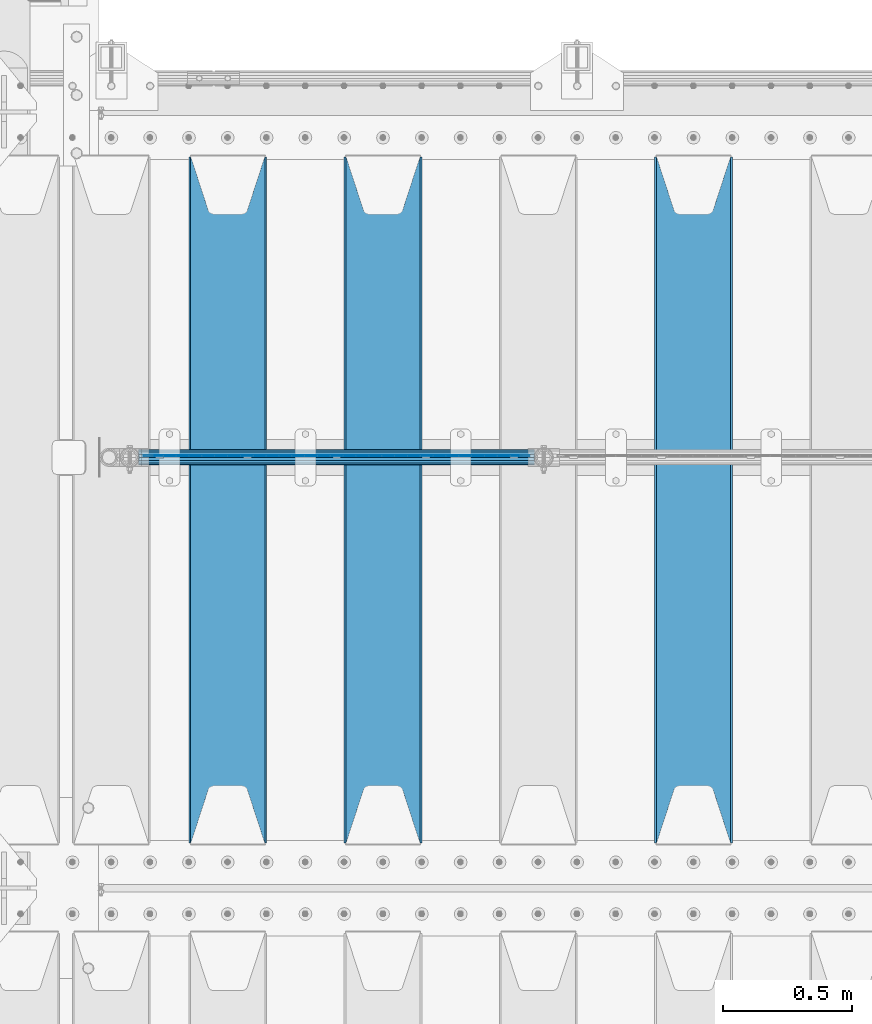
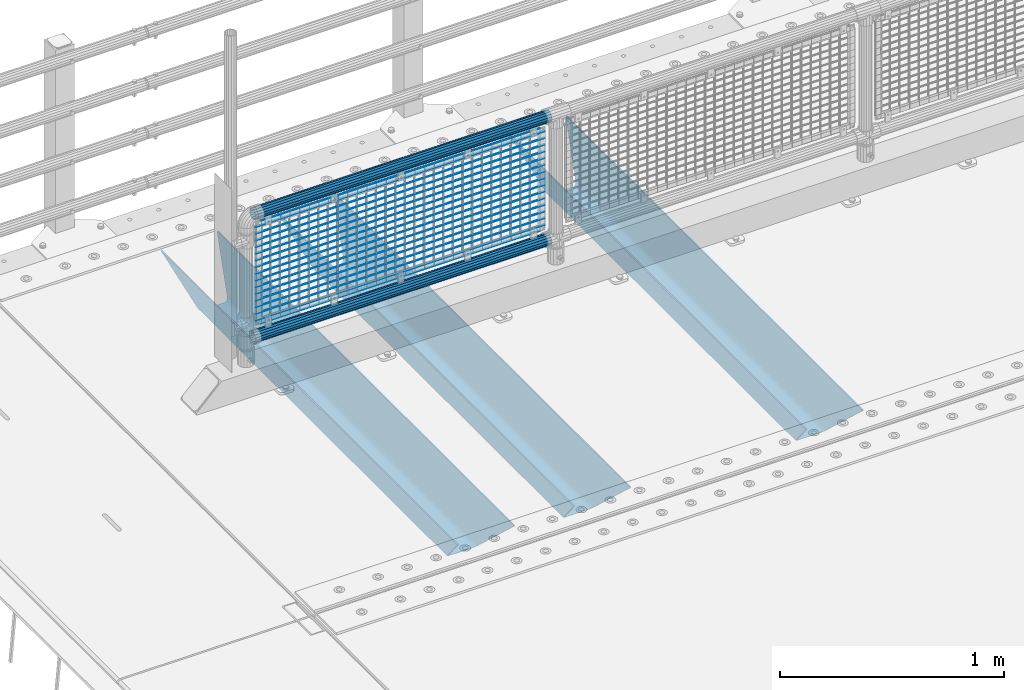
# One storey, part 120 of 247: 22 beams.
"""IFC2X3 building model written with IfcOpenShell, lengths in millimetres."""

from ifc_helpers import new_model, si_unit, frame, origin_with_axes, place, context, subcontext, project, spatial, faceted_brep, material, type_object, element, save


model = new_model("IFC2X3")

# Units and contexts
model_context = context("Model", 3, precision=1e-05, world=origin_with_axes())
body_context = subcontext(model_context, "Body", "Model", "MODEL_VIEW")
ifc_project = project(units=[si_unit("LENGTHUNIT", "METRE", prefix="MILLI"), si_unit("AREAUNIT", "SQUARE_METRE"), si_unit("VOLUMEUNIT", "CUBIC_METRE"), si_unit("MASSUNIT", "GRAM", prefix="KILO"), si_unit("TIMEUNIT", "SECOND"), si_unit("PLANEANGLEUNIT", "RADIAN"), si_unit("SOLIDANGLEUNIT", "STERADIAN"), si_unit("THERMODYNAMICTEMPERATUREUNIT", "DEGREE_CELSIUS"), si_unit("LUMINOUSINTENSITYUNIT", "LUMEN")], contexts=[model_context])

# Site, building, storey
site_placement = place(None, origin_with_axes())
site = spatial("IfcSite", under=ifc_project, at=site_placement, CompositionType="ELEMENT")
building_placement = place(site_placement, origin_with_axes())
building = spatial("IfcBuilding", under=site, at=building_placement, Name="Standard", CompositionType="ELEMENT")
storey_placement = place(building_placement, origin_with_axes())
storey = spatial("IfcBuildingStorey", under=building, at=storey_placement, Name="Undefined", CompositionType="ELEMENT", Elevation=0.0)

# Beams
ifc_material_1 = material(Name="STEEL/S355N")
beam_type_1 = type_object("IfcBeamType", PredefinedType="NOTDEFINED")
beam_1_placement = place(storey_placement, frame((2800.0, 6175.0, -115.0), z_axis=(0.0, 0.0, 1.0), x_axis=(0.0, 1.0, 0.0)))
element("IfcBeam", 1, at=beam_1_placement, inside=storey, type_object=beam_type_1, material=ifc_material_1, context=body_context, shape_type="Brep", body=[
    faceted_brep([(0.0, 150.0, 115.0), (0.0, 143.689999999999, 115.0), (2650.00000000297, 143.689999999999, 115.0), (2650.00000000297, 150.0, 115.0), (2650.00000000297, 142.059565218402, 110.0000000031), (2650.00000000297, 148.369565218403, 110.0000000031), (2441.90079219208, -80.1103600731112, -98.0992078077845), (2437.7588105432, -77.5672621345584, -102.241189456673), (2434.06523489746, -74.4080125315522, -105.934765102404), (2430.91086095089, -70.710272125576, -109.089139048974), (2428.37322971128, -66.5649389910068, -111.626770288588), (2426.51472138054, -62.0739139532889, -113.485278619323), (2425.38102192091, -57.3475956567672, -114.618978078955), (2424.99999999987, -52.5021667386536, -115.0), (2424.99999999987, 52.5021667386536, -115.0), (2425.38102192091, 57.3475956567672, -114.618978078955), (2426.51472138054, 62.0739139532889, -113.485278619323), (2428.37322971128, 66.5649389910068, -111.626770288588), (2430.91086095089, 70.710272125576, -109.089139048974), (2434.06523489746, 74.4080125315522, -105.934765102404), (2437.7588105432, 77.5672621345584, -102.241189456673), (2441.90079219208, 80.1103600731112, -98.0992078077846), (2446.38936140511, 81.9747917625791, -93.6106385947584), (2448.24948500409, 76.2713538057251, -91.7505149957729), (2444.62967112262, 74.76777986261, -95.3703288772456), (2441.28936334126, 72.7168944282894, -98.710636658607), (2438.31067330438, 70.1691124903846, -101.689326695487), (2435.76682334747, 67.1870637758839, -104.233176652398), (2433.72034654133, 63.8440531834895, -106.279653458539), (2432.22154950041, 60.222258798236, -107.778450499454), (2431.30727574265, 56.4107117849089, -108.692724257221), (2430.99999999987, 52.5031078186876, -109.0), (2430.99999999987, -52.5031078186876, -109.0), (2431.30727574265, -56.4107117849089, -108.692724257221), (2432.22154950041, -60.222258798236, -107.778450499454), (2433.72034654133, -63.8440531834895, -106.279653458539), (2435.76682334747, -67.1870637758839, -104.233176652398), (2438.31067330438, -70.1691124903846, -101.689326695487), (2441.28936334126, -72.7168944282894, -98.7106366586071), (2444.62967112262, -74.76777986261, -95.3703288772457), (2448.24948500409, -76.2713538057251, -91.7505149957729), (2650.00000000297, -142.059565218402, 110.0000000031), (2650.00000000297, -148.369565218403, 110.0000000031), (2446.38936140511, -81.9747917625791, -93.6106385947584), (2650.00000000297, -143.689999999999, 115.0), (2650.00000000297, -150.0, 115.0), (0.0, -143.689999999999, 115.0), (0.0, -150.0, 115.0), (0.0, -148.369565218261, 110.000000002663), (203.610638597422, -81.9747917625791, -93.6106385947584), (208.099207810448, -80.1103600731112, -98.0992078077845), (212.241189459336, -77.5672621345584, -102.241189456673), (215.934765105068, -74.4080125315522, -105.934765102404), (219.089139051637, -70.710272125576, -109.089139048974), (221.626770291251, -66.5649389910068, -111.626770288588), (223.485278621985, -62.0739139532889, -113.485278619323), (224.618978081617, -57.3475956567672, -114.618978078955), (225.000000002663, -52.5021667386536, -115.0), (225.000000002663, 52.5021667386536, -115.0), (224.618978081617, 57.3475956567672, -114.618978078955), (223.485278621985, 62.0739139532889, -113.485278619323), (221.626770291251, 66.5649389910068, -111.626770288588), (219.089139051637, 70.710272125576, -109.089139048974), (215.934765105068, 74.4080125315522, -105.934765102404), (212.241189459336, 77.5672621345584, -102.241189456673), (208.099207810448, 80.1103600731112, -98.0992078077846), (203.610638597422, 81.9747917625791, -93.6106385947584), (0.0, 148.369565218261, 110.000000002663), (0.0, 142.05956521826, 110.000000002663), (201.750514998436, 76.2713538057251, -91.7505149957729), (205.370328879908, 74.76777986261, -95.3703288772456), (208.710636661271, 72.7168944282894, -98.710636658607), (211.68932669815, 70.1691124903846, -101.689326695487), (214.233176655061, 67.1870637758839, -104.233176652398), (216.279653461202, 63.8440531834895, -106.279653458539), (217.778450502117, 60.222258798236, -107.778450499454), (218.692724259885, 56.4107117849089, -108.692724257221), (219.000000002663, 52.5031078186876, -109.0), (219.000000002663, -52.5031078186876, -109.0), (218.692724259885, -56.4107117849089, -108.692724257221), (217.778450502117, -60.222258798236, -107.778450499454), (216.279653461202, -63.8440531834895, -106.279653458539), (214.233176655061, -67.1870637758839, -104.233176652398), (211.68932669815, -70.1691124903846, -101.689326695487), (208.710636661271, -72.7168944282894, -98.7106366586071), (205.370328879908, -74.76777986261, -95.3703288772457), (201.750514998436, -76.2713538057251, -91.7505149957729), (0.0, -142.05956521826, 110.000000002663)], [[[0, 1, 2, 3]], [[3, 2, 4, 5]], [[6, 7, 8, 9, 10, 11, 12, 13, 14, 15, 16, 17, 18, 19, 20, 21, 22, 5, 4, 23, 24, 25, 26, 27, 28, 29, 30, 31, 32, 33, 34, 35, 36, 37, 38, 39, 40, 41, 42, 43]], [[44, 45, 42, 41]], [[46, 47, 45, 44]], [[43, 42, 45, 47, 48, 49]], [[6, 43, 49, 50]], [[7, 6, 50, 51]], [[8, 7, 51, 52]], [[9, 8, 52, 53]], [[10, 9, 53, 54]], [[11, 10, 54, 55]], [[12, 11, 55, 56]], [[13, 12, 56, 57]], [[14, 13, 57, 58]], [[15, 14, 58, 59]], [[16, 15, 59, 60]], [[17, 16, 60, 61]], [[18, 17, 61, 62]], [[19, 18, 62, 63]], [[20, 19, 63, 64]], [[21, 20, 64, 65]], [[22, 21, 65, 66]], [[0, 3, 5, 22, 66, 67]], [[1, 0, 67, 68]], [[23, 4, 2, 1, 68, 69]], [[24, 23, 69, 70]], [[25, 24, 70, 71]], [[26, 25, 71, 72]], [[27, 26, 72, 73]], [[28, 27, 73, 74]], [[29, 28, 74, 75]], [[30, 29, 75, 76]], [[31, 30, 76, 77]], [[32, 31, 77, 78]], [[33, 32, 78, 79]], [[34, 33, 79, 80]], [[35, 34, 80, 81]], [[36, 35, 81, 82]], [[37, 36, 82, 83]], [[38, 37, 83, 84]], [[39, 38, 84, 85]], [[40, 39, 85, 86]], [[46, 44, 41, 40, 86, 87]], [[47, 46, 87, 48]], [[86, 85, 84, 83, 82, 81, 80, 79, 78, 77, 76, 75, 74, 73, 72, 71, 70, 69, 68, 67, 66, 65, 64, 63, 62, 61, 60, 59, 58, 57, 56, 55, 54, 53, 52, 51, 50, 49, 48, 87]]]),
])
beam_2_placement = place(storey_placement, frame((1600.0, 6175.0, -115.0), z_axis=(0.0, 0.0, 1.0), x_axis=(0.0, 1.0, 0.0)))
element("IfcBeam", 2, at=beam_2_placement, inside=storey, type_object=beam_type_1, material=ifc_material_1, context=body_context, shape_type="Brep", body=[
    faceted_brep([(0.0, 150.0, 115.0), (0.0, 143.689999999999, 115.0), (2650.00000000297, 143.689999999999, 115.0), (2650.00000000297, 150.0, 115.0), (2650.00000000297, 142.059565218402, 110.0000000031), (2650.00000000297, 148.369565218403, 110.0000000031), (2441.90079219208, -80.1103600731112, -98.0992078077845), (2437.7588105432, -77.5672621345584, -102.241189456673), (2434.06523489746, -74.4080125315522, -105.934765102404), (2430.91086095089, -70.710272125576, -109.089139048974), (2428.37322971128, -66.5649389910068, -111.626770288588), (2426.51472138054, -62.0739139532889, -113.485278619323), (2425.38102192091, -57.3475956567672, -114.618978078955), (2424.99999999987, -52.5021667386536, -115.0), (2424.99999999987, 52.5021667386536, -115.0), (2425.38102192091, 57.3475956567672, -114.618978078955), (2426.51472138054, 62.0739139532889, -113.485278619323), (2428.37322971128, 66.5649389910068, -111.626770288588), (2430.91086095089, 70.710272125576, -109.089139048974), (2434.06523489746, 74.4080125315522, -105.934765102404), (2437.7588105432, 77.5672621345584, -102.241189456673), (2441.90079219208, 80.1103600731112, -98.0992078077846), (2446.38936140511, 81.9747917625791, -93.6106385947584), (2448.24948500409, 76.2713538057251, -91.7505149957729), (2444.62967112262, 74.76777986261, -95.3703288772456), (2441.28936334126, 72.7168944282894, -98.710636658607), (2438.31067330438, 70.1691124903846, -101.689326695487), (2435.76682334747, 67.1870637758839, -104.233176652398), (2433.72034654133, 63.8440531834895, -106.279653458539), (2432.22154950041, 60.222258798236, -107.778450499454), (2431.30727574265, 56.4107117849089, -108.692724257221), (2430.99999999987, 52.5031078186876, -109.0), (2430.99999999987, -52.5031078186876, -109.0), (2431.30727574265, -56.4107117849089, -108.692724257221), (2432.22154950041, -60.222258798236, -107.778450499454), (2433.72034654133, -63.8440531834895, -106.279653458539), (2435.76682334747, -67.1870637758839, -104.233176652398), (2438.31067330438, -70.1691124903846, -101.689326695487), (2441.28936334126, -72.7168944282894, -98.7106366586071), (2444.62967112262, -74.76777986261, -95.3703288772457), (2448.24948500409, -76.2713538057251, -91.7505149957729), (2650.00000000297, -142.059565218402, 110.0000000031), (2650.00000000297, -148.369565218403, 110.0000000031), (2446.38936140511, -81.9747917625791, -93.6106385947584), (2650.00000000297, -143.689999999999, 115.0), (2650.00000000297, -150.0, 115.0), (0.0, -143.689999999999, 115.0), (0.0, -150.0, 115.0), (0.0, -148.369565218261, 110.000000002663), (203.610638597422, -81.9747917625791, -93.6106385947584), (208.099207810448, -80.1103600731112, -98.0992078077845), (212.241189459336, -77.5672621345584, -102.241189456673), (215.934765105068, -74.4080125315522, -105.934765102404), (219.089139051637, -70.710272125576, -109.089139048974), (221.626770291251, -66.5649389910068, -111.626770288588), (223.485278621985, -62.0739139532889, -113.485278619323), (224.618978081617, -57.3475956567672, -114.618978078955), (225.000000002663, -52.5021667386536, -115.0), (225.000000002663, 52.5021667386536, -115.0), (224.618978081617, 57.3475956567672, -114.618978078955), (223.485278621985, 62.0739139532889, -113.485278619323), (221.626770291251, 66.5649389910068, -111.626770288588), (219.089139051637, 70.710272125576, -109.089139048974), (215.934765105068, 74.4080125315522, -105.934765102404), (212.241189459336, 77.5672621345584, -102.241189456673), (208.099207810448, 80.1103600731112, -98.0992078077846), (203.610638597422, 81.9747917625791, -93.6106385947584), (0.0, 148.369565218261, 110.000000002663), (0.0, 142.05956521826, 110.000000002663), (201.750514998436, 76.2713538057251, -91.7505149957729), (205.370328879908, 74.76777986261, -95.3703288772456), (208.710636661271, 72.7168944282894, -98.710636658607), (211.68932669815, 70.1691124903846, -101.689326695487), (214.233176655061, 67.1870637758839, -104.233176652398), (216.279653461202, 63.8440531834895, -106.279653458539), (217.778450502117, 60.222258798236, -107.778450499454), (218.692724259885, 56.4107117849089, -108.692724257221), (219.000000002663, 52.5031078186876, -109.0), (219.000000002663, -52.5031078186876, -109.0), (218.692724259885, -56.4107117849089, -108.692724257221), (217.778450502117, -60.222258798236, -107.778450499454), (216.279653461202, -63.8440531834895, -106.279653458539), (214.233176655061, -67.1870637758839, -104.233176652398), (211.68932669815, -70.1691124903846, -101.689326695487), (208.710636661271, -72.7168944282894, -98.7106366586071), (205.370328879908, -74.76777986261, -95.3703288772457), (201.750514998436, -76.2713538057251, -91.7505149957729), (0.0, -142.05956521826, 110.000000002663)], [[[0, 1, 2, 3]], [[3, 2, 4, 5]], [[6, 7, 8, 9, 10, 11, 12, 13, 14, 15, 16, 17, 18, 19, 20, 21, 22, 5, 4, 23, 24, 25, 26, 27, 28, 29, 30, 31, 32, 33, 34, 35, 36, 37, 38, 39, 40, 41, 42, 43]], [[44, 45, 42, 41]], [[46, 47, 45, 44]], [[43, 42, 45, 47, 48, 49]], [[6, 43, 49, 50]], [[7, 6, 50, 51]], [[8, 7, 51, 52]], [[9, 8, 52, 53]], [[10, 9, 53, 54]], [[11, 10, 54, 55]], [[12, 11, 55, 56]], [[13, 12, 56, 57]], [[14, 13, 57, 58]], [[15, 14, 58, 59]], [[16, 15, 59, 60]], [[17, 16, 60, 61]], [[18, 17, 61, 62]], [[19, 18, 62, 63]], [[20, 19, 63, 64]], [[21, 20, 64, 65]], [[22, 21, 65, 66]], [[0, 3, 5, 22, 66, 67]], [[1, 0, 67, 68]], [[23, 4, 2, 1, 68, 69]], [[24, 23, 69, 70]], [[25, 24, 70, 71]], [[26, 25, 71, 72]], [[27, 26, 72, 73]], [[28, 27, 73, 74]], [[29, 28, 74, 75]], [[30, 29, 75, 76]], [[31, 30, 76, 77]], [[32, 31, 77, 78]], [[33, 32, 78, 79]], [[34, 33, 79, 80]], [[35, 34, 80, 81]], [[36, 35, 81, 82]], [[37, 36, 82, 83]], [[38, 37, 83, 84]], [[39, 38, 84, 85]], [[40, 39, 85, 86]], [[46, 44, 41, 40, 86, 87]], [[47, 46, 87, 48]], [[86, 85, 84, 83, 82, 81, 80, 79, 78, 77, 76, 75, 74, 73, 72, 71, 70, 69, 68, 67, 66, 65, 64, 63, 62, 61, 60, 59, 58, 57, 56, 55, 54, 53, 52, 51, 50, 49, 48, 87]]]),
])
beam_3_placement = place(storey_placement, frame((1000.0, 6175.0, -115.0), z_axis=(0.0, 0.0, 1.0), x_axis=(0.0, 1.0, 0.0)))
element("IfcBeam", 3, at=beam_3_placement, inside=storey, type_object=beam_type_1, material=ifc_material_1, context=body_context, shape_type="Brep", body=[
    faceted_brep([(0.0, 150.0, 115.0), (0.0, 143.689999999999, 115.0), (2650.00000000297, 143.689999999999, 115.0), (2650.00000000297, 150.0, 115.0), (2650.00000000297, 142.059565218402, 110.0000000031), (2650.00000000297, 148.369565218403, 110.0000000031), (2441.90079219208, -80.1103600731112, -98.0992078077845), (2437.7588105432, -77.5672621345584, -102.241189456673), (2434.06523489746, -74.4080125315522, -105.934765102404), (2430.91086095089, -70.710272125576, -109.089139048974), (2428.37322971128, -66.5649389910068, -111.626770288588), (2426.51472138054, -62.0739139532889, -113.485278619323), (2425.38102192091, -57.3475956567672, -114.618978078955), (2424.99999999987, -52.5021667386536, -115.0), (2424.99999999987, 52.5021667386536, -115.0), (2425.38102192091, 57.3475956567672, -114.618978078955), (2426.51472138054, 62.0739139532889, -113.485278619323), (2428.37322971128, 66.5649389910068, -111.626770288588), (2430.91086095089, 70.710272125576, -109.089139048974), (2434.06523489746, 74.4080125315522, -105.934765102404), (2437.7588105432, 77.5672621345584, -102.241189456673), (2441.90079219208, 80.1103600731112, -98.0992078077846), (2446.38936140511, 81.9747917625791, -93.6106385947584), (2448.24948500409, 76.2713538057251, -91.7505149957729), (2444.62967112262, 74.76777986261, -95.3703288772456), (2441.28936334126, 72.7168944282894, -98.710636658607), (2438.31067330438, 70.1691124903846, -101.689326695487), (2435.76682334747, 67.1870637758839, -104.233176652398), (2433.72034654133, 63.8440531834895, -106.279653458539), (2432.22154950041, 60.222258798236, -107.778450499454), (2431.30727574265, 56.4107117849089, -108.692724257221), (2430.99999999987, 52.5031078186876, -109.0), (2430.99999999987, -52.5031078186876, -109.0), (2431.30727574265, -56.4107117849089, -108.692724257221), (2432.22154950041, -60.222258798236, -107.778450499454), (2433.72034654133, -63.8440531834895, -106.279653458539), (2435.76682334747, -67.1870637758839, -104.233176652398), (2438.31067330438, -70.1691124903846, -101.689326695487), (2441.28936334126, -72.7168944282894, -98.7106366586071), (2444.62967112262, -74.76777986261, -95.3703288772457), (2448.24948500409, -76.2713538057251, -91.7505149957729), (2650.00000000297, -142.059565218402, 110.0000000031), (2650.00000000297, -148.369565218403, 110.0000000031), (2446.38936140511, -81.9747917625791, -93.6106385947584), (2650.00000000297, -143.689999999999, 115.0), (2650.00000000297, -150.0, 115.0), (0.0, -143.689999999999, 115.0), (0.0, -150.0, 115.0), (0.0, -148.369565218261, 110.000000002663), (203.610638597422, -81.9747917625791, -93.6106385947584), (208.099207810448, -80.1103600731112, -98.0992078077845), (212.241189459336, -77.5672621345584, -102.241189456673), (215.934765105068, -74.4080125315522, -105.934765102404), (219.089139051637, -70.710272125576, -109.089139048974), (221.626770291251, -66.5649389910068, -111.626770288588), (223.485278621985, -62.0739139532889, -113.485278619323), (224.618978081617, -57.3475956567672, -114.618978078955), (225.000000002663, -52.5021667386536, -115.0), (225.000000002663, 52.5021667386536, -115.0), (224.618978081617, 57.3475956567672, -114.618978078955), (223.485278621985, 62.0739139532889, -113.485278619323), (221.626770291251, 66.5649389910068, -111.626770288588), (219.089139051637, 70.710272125576, -109.089139048974), (215.934765105068, 74.4080125315522, -105.934765102404), (212.241189459336, 77.5672621345584, -102.241189456673), (208.099207810448, 80.1103600731112, -98.0992078077846), (203.610638597422, 81.9747917625791, -93.6106385947584), (0.0, 148.369565218261, 110.000000002663), (0.0, 142.05956521826, 110.000000002663), (201.750514998436, 76.2713538057251, -91.7505149957729), (205.370328879908, 74.76777986261, -95.3703288772456), (208.710636661271, 72.7168944282894, -98.710636658607), (211.68932669815, 70.1691124903846, -101.689326695487), (214.233176655061, 67.1870637758839, -104.233176652398), (216.279653461202, 63.8440531834895, -106.279653458539), (217.778450502117, 60.222258798236, -107.778450499454), (218.692724259885, 56.4107117849089, -108.692724257221), (219.000000002663, 52.5031078186876, -109.0), (219.000000002663, -52.5031078186876, -109.0), (218.692724259885, -56.4107117849089, -108.692724257221), (217.778450502117, -60.222258798236, -107.778450499454), (216.279653461202, -63.8440531834895, -106.279653458539), (214.233176655061, -67.1870637758839, -104.233176652398), (211.68932669815, -70.1691124903846, -101.689326695487), (208.710636661271, -72.7168944282894, -98.7106366586071), (205.370328879908, -74.76777986261, -95.3703288772457), (201.750514998436, -76.2713538057251, -91.7505149957729), (0.0, -142.05956521826, 110.000000002663)], [[[0, 1, 2, 3]], [[3, 2, 4, 5]], [[6, 7, 8, 9, 10, 11, 12, 13, 14, 15, 16, 17, 18, 19, 20, 21, 22, 5, 4, 23, 24, 25, 26, 27, 28, 29, 30, 31, 32, 33, 34, 35, 36, 37, 38, 39, 40, 41, 42, 43]], [[44, 45, 42, 41]], [[46, 47, 45, 44]], [[43, 42, 45, 47, 48, 49]], [[6, 43, 49, 50]], [[7, 6, 50, 51]], [[8, 7, 51, 52]], [[9, 8, 52, 53]], [[10, 9, 53, 54]], [[11, 10, 54, 55]], [[12, 11, 55, 56]], [[13, 12, 56, 57]], [[14, 13, 57, 58]], [[15, 14, 58, 59]], [[16, 15, 59, 60]], [[17, 16, 60, 61]], [[18, 17, 61, 62]], [[19, 18, 62, 63]], [[20, 19, 63, 64]], [[21, 20, 64, 65]], [[22, 21, 65, 66]], [[0, 3, 5, 22, 66, 67]], [[1, 0, 67, 68]], [[23, 4, 2, 1, 68, 69]], [[24, 23, 69, 70]], [[25, 24, 70, 71]], [[26, 25, 71, 72]], [[27, 26, 72, 73]], [[28, 27, 73, 74]], [[29, 28, 74, 75]], [[30, 29, 75, 76]], [[31, 30, 76, 77]], [[32, 31, 77, 78]], [[33, 32, 78, 79]], [[34, 33, 79, 80]], [[35, 34, 80, 81]], [[36, 35, 81, 82]], [[37, 36, 82, 83]], [[38, 37, 83, 84]], [[39, 38, 84, 85]], [[40, 39, 85, 86]], [[46, 44, 41, 40, 86, 87]], [[47, 46, 87, 48]], [[86, 85, 84, 83, 82, 81, 80, 79, 78, 77, 76, 75, 74, 73, 72, 71, 70, 69, 68, 67, 66, 65, 64, 63, 62, 61, 60, 59, 58, 57, 56, 55, 54, 53, 52, 51, 50, 49, 48, 87]]]),
])
ifc_material_2 = material()
beam_type_2 = type_object("IfcBeamType", PredefinedType="NOTDEFINED")
beam_4_placement = place(storey_placement, frame((655.85, 7664.5, 969.849999999999), z_axis=(0.0, 0.0, 1.0), x_axis=(1.0, 0.0, 0.0)))
element("IfcBeam", 4, at=beam_4_placement, inside=storey, type_object=beam_type_2, material=ifc_material_2, context=body_context, shape_type="Brep", body=[
    faceted_brep([(0.0, -25.3500000000004, 0.0), (0.0, -23.4203461491616, 9.70102501045585), (1530.0, -23.4203461491616, 9.70102501045506), (1530.0, -25.3500000000004, 0.0), (0.0, -17.9251569030794, 17.9251569030785), (1530.0, -17.9251569030794, 17.925156903079), (0.0, -9.70102501045494, 23.4203461491616), (1530.0, -9.70102501045494, 23.4203461491611), (0.0, 0.0, 25.3500000000004), (1530.0, 0.0, 25.35), (0.0, 9.70102501045494, 23.4203461491616), (1530.0, 9.70102501045494, 23.4203461491611), (0.0, 17.9251569030794, 17.9251569030785), (1530.0, 17.9251569030794, 17.925156903079), (0.0, 23.4203461491616, 9.70102501045585), (1530.0, 23.4203461491616, 9.70102501045506), (0.0, 25.3500000000004, 0.0), (1530.0, 25.3500000000004, 0.0), (0.0, 23.4203461491616, -9.70102501045585), (1530.0, 23.4203461491616, -9.70102501045506), (0.0, 17.9251569030794, -17.9251569030785), (1530.0, 17.9251569030794, -17.925156903079), (0.0, 9.70102501045494, -23.4203461491616), (1530.0, 9.70102501045494, -23.4203461491611), (0.0, 0.0, -25.3500000000004), (1530.0, 0.0, -25.35), (0.0, -9.70102501045494, -23.4203461491616), (1530.0, -9.70102501045494, -23.4203461491611), (0.0, -17.9251569030794, -17.9251569030785), (1530.0, -17.9251569030794, -17.925156903079), (0.0, -23.4203461491616, -9.70102501045585), (1530.0, -23.4203461491616, -9.70102501045506), (0.0, -30.1499999999996, 0.0), (0.0, -27.8549679052148, -11.5379054858076), (1530.0, -27.8549679052148, -11.5379054858075), (1530.0, -30.1499999999996, 0.0), (0.0, -21.3192694527743, -21.3192694527752), (1530.0, -21.3192694527743, -21.3192694527744), (0.0, -11.5379054858076, -27.8549679052157), (1530.0, -11.5379054858076, -27.8549679052153), (0.0, 0.0, -30.1499999999996), (1530.0, 0.0, -30.15), (0.0, 11.5379054858076, -27.8549679052157), (1530.0, 11.5379054858076, -27.8549679052153), (0.0, 21.3192694527743, -21.3192694527752), (1530.0, 21.3192694527743, -21.3192694527744), (0.0, 27.8549679052157, -11.5379054858076), (1530.0, 27.8549679052157, -11.5379054858074), (0.0, 30.1499999999996, 0.0), (1530.0, 30.1499999999996, 0.0), (0.0, 27.8549679052157, 11.5379054858076), (1530.0, 27.8549679052157, 11.5379054858074), (0.0, 21.3192694527743, 21.3192694527752), (1530.0, 21.3192694527743, 21.3192694527744), (0.0, 11.5379054858076, 27.8549679052157), (1530.0, 11.5379054858076, 27.8549679052153), (0.0, 0.0, 30.1499999999996), (1530.0, 0.0, 30.15), (0.0, -11.5379054858076, 27.8549679052157), (1530.0, -11.5379054858076, 27.8549679052153), (0.0, -21.3192694527743, 21.3192694527752), (1530.0, -21.3192694527743, 21.3192694527744), (0.0, -27.8549679052157, 11.5379054858076), (1530.0, -27.8549679052157, 11.5379054858074)], [[[0, 1, 2, 3]], [[1, 4, 5, 2]], [[4, 6, 7, 5]], [[6, 8, 9, 7]], [[8, 10, 11, 9]], [[10, 12, 13, 11]], [[12, 14, 15, 13]], [[14, 16, 17, 15]], [[16, 18, 19, 17]], [[18, 20, 21, 19]], [[20, 22, 23, 21]], [[22, 24, 25, 23]], [[24, 26, 27, 25]], [[26, 28, 29, 27]], [[28, 30, 31, 29]], [[30, 0, 3, 31]], [[32, 33, 34, 35]], [[33, 36, 37, 34]], [[36, 38, 39, 37]], [[38, 40, 41, 39]], [[40, 42, 43, 41]], [[42, 44, 45, 43]], [[44, 46, 47, 45]], [[46, 48, 49, 47]], [[48, 50, 51, 49]], [[50, 52, 53, 51]], [[52, 54, 55, 53]], [[54, 56, 57, 55]], [[56, 58, 59, 57]], [[58, 60, 61, 59]], [[60, 62, 63, 61]], [[62, 32, 35, 63]], [[37, 39, 41, 43, 45, 47, 49, 51, 53, 55, 57, 59, 61, 63, 35, 34], [5, 7, 9, 11, 13, 15, 17, 19, 21, 23, 25, 27, 29, 31, 3, 2]], [[62, 60, 58, 56, 54, 52, 50, 48, 46, 44, 42, 40, 38, 36, 33, 32], [30, 28, 26, 24, 22, 20, 18, 16, 14, 12, 10, 8, 6, 4, 1, 0]]]),
])
beam_5_placement = place(storey_placement, frame((655.850000000006, 7664.5, 298.170000000001), z_axis=(0.0, 0.0, 1.0), x_axis=(1.0, 0.0, 0.0)))
element("IfcBeam", 5, at=beam_5_placement, inside=storey, type_object=beam_type_2, material=ifc_material_2, context=body_context, shape_type="Brep", body=[
    faceted_brep([(0.0, -25.3500000000004, 0.0), (0.0, -23.4203461491616, 9.70102501045585), (1530.0, -23.4203461491616, 9.70102501045506), (1530.0, -25.3500000000004, 0.0), (0.0, -17.9251569030794, 17.9251569030785), (1530.0, -17.9251569030794, 17.925156903079), (0.0, -9.70102501045494, 23.4203461491616), (1530.0, -9.70102501045494, 23.4203461491611), (0.0, 0.0, 25.3500000000004), (1530.0, 0.0, 25.35), (0.0, 9.70102501045494, 23.4203461491616), (1530.0, 9.70102501045494, 23.4203461491611), (0.0, 17.9251569030794, 17.9251569030785), (1530.0, 17.9251569030794, 17.925156903079), (0.0, 23.4203461491616, 9.70102501045585), (1530.0, 23.4203461491616, 9.70102501045506), (0.0, 25.3500000000004, 0.0), (1530.0, 25.3500000000004, 0.0), (0.0, 23.4203461491616, -9.70102501045585), (1530.0, 23.4203461491616, -9.70102501045506), (0.0, 17.9251569030794, -17.9251569030785), (1530.0, 17.9251569030794, -17.925156903079), (0.0, 9.70102501045494, -23.4203461491616), (1530.0, 9.70102501045494, -23.4203461491611), (0.0, 0.0, -25.3500000000004), (1530.0, 0.0, -25.35), (0.0, -9.70102501045494, -23.4203461491616), (1530.0, -9.70102501045494, -23.4203461491611), (0.0, -17.9251569030794, -17.9251569030785), (1530.0, -17.9251569030794, -17.925156903079), (0.0, -23.4203461491616, -9.70102501045585), (1530.0, -23.4203461491616, -9.70102501045506), (0.0, -30.1499999999996, 0.0), (0.0, -27.8549679052148, -11.5379054858076), (1530.0, -27.8549679052148, -11.5379054858075), (1530.0, -30.1499999999996, 0.0), (0.0, -21.3192694527743, -21.3192694527752), (1530.0, -21.3192694527743, -21.3192694527744), (0.0, -11.5379054858076, -27.8549679052157), (1530.0, -11.5379054858076, -27.8549679052153), (0.0, 0.0, -30.1499999999996), (1530.0, 0.0, -30.15), (0.0, 11.5379054858076, -27.8549679052157), (1530.0, 11.5379054858076, -27.8549679052153), (0.0, 21.3192694527743, -21.3192694527752), (1530.0, 21.3192694527743, -21.3192694527744), (0.0, 27.8549679052157, -11.5379054858076), (1530.0, 27.8549679052157, -11.5379054858074), (0.0, 30.1499999999996, 0.0), (1530.0, 30.1499999999996, 0.0), (0.0, 27.8549679052157, 11.5379054858076), (1530.0, 27.8549679052157, 11.5379054858074), (0.0, 21.3192694527743, 21.3192694527752), (1530.0, 21.3192694527743, 21.3192694527744), (0.0, 11.5379054858076, 27.8549679052157), (1530.0, 11.5379054858076, 27.8549679052153), (0.0, 0.0, 30.1499999999996), (1530.0, 0.0, 30.15), (0.0, -11.5379054858076, 27.8549679052157), (1530.0, -11.5379054858076, 27.8549679052153), (0.0, -21.3192694527743, 21.3192694527752), (1530.0, -21.3192694527743, 21.3192694527744), (0.0, -27.8549679052157, 11.5379054858076), (1530.0, -27.8549679052157, 11.5379054858074)], [[[0, 1, 2, 3]], [[1, 4, 5, 2]], [[4, 6, 7, 5]], [[6, 8, 9, 7]], [[8, 10, 11, 9]], [[10, 12, 13, 11]], [[12, 14, 15, 13]], [[14, 16, 17, 15]], [[16, 18, 19, 17]], [[18, 20, 21, 19]], [[20, 22, 23, 21]], [[22, 24, 25, 23]], [[24, 26, 27, 25]], [[26, 28, 29, 27]], [[28, 30, 31, 29]], [[30, 0, 3, 31]], [[32, 33, 34, 35]], [[33, 36, 37, 34]], [[36, 38, 39, 37]], [[38, 40, 41, 39]], [[40, 42, 43, 41]], [[42, 44, 45, 43]], [[44, 46, 47, 45]], [[46, 48, 49, 47]], [[48, 50, 51, 49]], [[50, 52, 53, 51]], [[52, 54, 55, 53]], [[54, 56, 57, 55]], [[56, 58, 59, 57]], [[58, 60, 61, 59]], [[60, 62, 63, 61]], [[62, 32, 35, 63]], [[37, 39, 41, 43, 45, 47, 49, 51, 53, 55, 57, 59, 61, 63, 35, 34], [5, 7, 9, 11, 13, 15, 17, 19, 21, 23, 25, 27, 29, 31, 3, 2]], [[62, 60, 58, 56, 54, 52, 50, 48, 46, 44, 42, 40, 38, 36, 33, 32], [30, 28, 26, 24, 22, 20, 18, 16, 14, 12, 10, 8, 6, 4, 1, 0]]]),
])
ifc_material_3 = material(Name="Misc_Undefined")
beam_type_3 = type_object("IfcBeamType", Name="D3", PredefinedType="NOTDEFINED")
for number, where, z_axis, x_axis in (
    (6, (676.0, 7670.5, 851.596999999999), (0.0, 0.0, 1.0), (1.0, 0.0, 0.0)),
    (7, (676.0, 7670.5, 669.452), (0.0, 0.0, 1.0), (1.0, 0.0, 0.0)),
    (8, (676.0, 7670.5, 523.736), (0.0, 0.0, 1.0), (1.0, 0.0, 0.0)),
    (9, (676.0, 7670.5, 487.307), (0.0, 0.0, 1.0), (1.0, 0.0, 0.0)),
    (10, (676.0, 7670.5, 705.881), (0.0, 0.0, 1.0), (1.0, 0.0, 0.0)),
    (11, (676.0, 7670.5, 596.594), (0.0, 0.0, 1.0), (1.0, 0.0, 0.0)),
    (12, (676.0, 7670.5, 450.878), (0.0, 0.0, 1.0), (1.0, 0.0, 0.0)),
    (13, (676.0, 7670.5, 815.167999999999), (0.0, 0.0, 1.0), (1.0, 0.0, 0.0)),
    (14, (676.0, 7670.5, 888.025999999999), (0.0, 0.0, 1.0), (1.0, 0.0, 0.0)),
    (15, (676.0, 7670.5, 778.738999999999), (0.0, 0.0, 1.0), (1.0, 0.0, 0.0)),
    (16, (676.0, 7670.5, 742.309999999999), (0.0, 0.0, 1.0), (1.0, 0.0, 0.0)),
    (17, (676.0, 7670.5, 633.023), (0.0, 0.0, 1.0), (1.0, 0.0, 0.0)),
    (18, (676.0, 7670.5, 560.165), (0.0, 0.0, 1.0), (1.0, 0.0, 0.0)),
    (19, (676.0, 7670.5, 414.449), (0.0, 0.0, 1.0), (1.0, 0.0, 0.0)),
):
    element("IfcBeam", number, at=place(storey_placement, frame(where, z_axis=z_axis, x_axis=x_axis)), inside=storey, type_object=beam_type_3, material=ifc_material_3, ObjectType="D3", context=body_context, shape_type="Brep", body=[
        faceted_brep([(1.81898940354586e-12, -1.5, -5.6843418860808e-14), (0.0, -0.75, -1.29903810567703), (1490.0, -0.75, -1.29903810567669), (1490.0, -1.5, 0.0), (0.0, 0.75, -1.29903810567703), (1490.0, 0.75, -1.29903810567669), (1.81898940354586e-12, 1.5, -5.6843418860808e-14), (1490.0, 1.5, 0.0), (0.0, 0.75, 1.29903810567703), (1490.0, 0.75, 1.29903810567669), (0.0, -0.75, 1.29903810567703), (1490.0, -0.75, 1.29903810567669)], [[[0, 1, 2, 3]], [[1, 4, 5, 2]], [[4, 6, 7, 5]], [[6, 8, 9, 7]], [[8, 10, 11, 9]], [[10, 0, 3, 11]], [[5, 7, 9, 11, 3, 2]], [[10, 8, 6, 4, 1, 0]]]),
    ])
beam_6_placement = place(storey_placement, frame((701.0, 7670.5, 353.02), z_axis=(0.0, 0.0, 1.0), x_axis=(1.0, 0.0, 0.0)))
element("IfcBeam", 20, at=beam_6_placement, inside=storey, type_object=beam_type_3, material=ifc_material_3, ObjectType="D3", context=body_context, shape_type="Brep", body=[
    faceted_brep([(1.81898940354586e-12, -1.5, -5.6843418860808e-14), (0.0, -0.75, -1.29903810567703), (1440.0, -0.75, -1.29903810567669), (1440.0, -1.5, 0.0), (0.0, 0.75, -1.29903810567703), (1440.0, 0.75, -1.29903810567663), (1.81898940354586e-12, 1.5, -5.6843418860808e-14), (1440.0, 1.5, 0.0), (0.0, 0.75, 1.29903810567703), (1440.0, 0.75, 1.29903810567669), (0.0, -0.75, 1.29903810567703), (1440.0, -0.75, 1.29903810567669)], [[[0, 1, 2, 3]], [[1, 4, 5, 2]], [[4, 6, 7, 5]], [[6, 8, 9, 7]], [[8, 10, 11, 9]], [[10, 0, 3, 11]], [[5, 7, 9, 11, 3, 2]], [[10, 8, 6, 4, 1, 0]]]),
])
beam_7_placement = place(storey_placement, frame((676.0, 7670.5, 378.02), z_axis=(0.0, 0.0, 1.0), x_axis=(1.0, 0.0, 0.0)))
element("IfcBeam", 21, at=beam_7_placement, inside=storey, type_object=beam_type_3, material=ifc_material_3, ObjectType="D3", context=body_context, shape_type="Brep", body=[
    faceted_brep([(1.81898940354586e-12, -1.5, -5.6843418860808e-14), (0.0, -0.75, -1.29903810567703), (1490.0, -0.75, -1.29903810567669), (1490.0, -1.5, 0.0), (0.0, 0.75, -1.29903810567703), (1490.0, 0.75, -1.29903810567669), (1.81898940354586e-12, 1.5, -5.6843418860808e-14), (1490.0, 1.5, 0.0), (0.0, 0.75, 1.29903810567703), (1490.0, 0.75, 1.29903810567669), (0.0, -0.75, 1.29903810567703), (1490.0, -0.75, 1.29903810567669)], [[[0, 1, 2, 3]], [[1, 4, 5, 2]], [[4, 6, 7, 5]], [[6, 8, 9, 7]], [[8, 10, 11, 9]], [[10, 0, 3, 11]], [[5, 7, 9, 11, 3, 2]], [[10, 8, 6, 4, 1, 0]]]),
])
beam_8_placement = place(storey_placement, frame((701.0, 7670.5, 913.02), z_axis=(0.0, 0.0, 1.0), x_axis=(1.0, 0.0, 0.0)))
element("IfcBeam", 22, at=beam_8_placement, inside=storey, type_object=beam_type_3, material=ifc_material_3, ObjectType="D3", context=body_context, shape_type="Brep", body=[
    faceted_brep([(1.81898940354586e-12, -1.5, -5.6843418860808e-14), (0.0, -0.75, -1.29903810567703), (1440.0, -0.75, -1.29903810567669), (1440.0, -1.5, 0.0), (0.0, 0.75, -1.29903810567703), (1440.0, 0.75, -1.29903810567663), (1.81898940354586e-12, 1.5, -5.6843418860808e-14), (1440.0, 1.5, 0.0), (0.0, 0.75, 1.29903810567703), (1440.0, 0.75, 1.29903810567669), (0.0, -0.75, 1.29903810567703), (1440.0, -0.75, 1.29903810567669)], [[[0, 1, 2, 3]], [[1, 4, 5, 2]], [[4, 6, 7, 5]], [[6, 8, 9, 7]], [[8, 10, 11, 9]], [[10, 0, 3, 11]], [[5, 7, 9, 11, 3, 2]], [[10, 8, 6, 4, 1, 0]]]),
])

save(model, "model.ifc")
